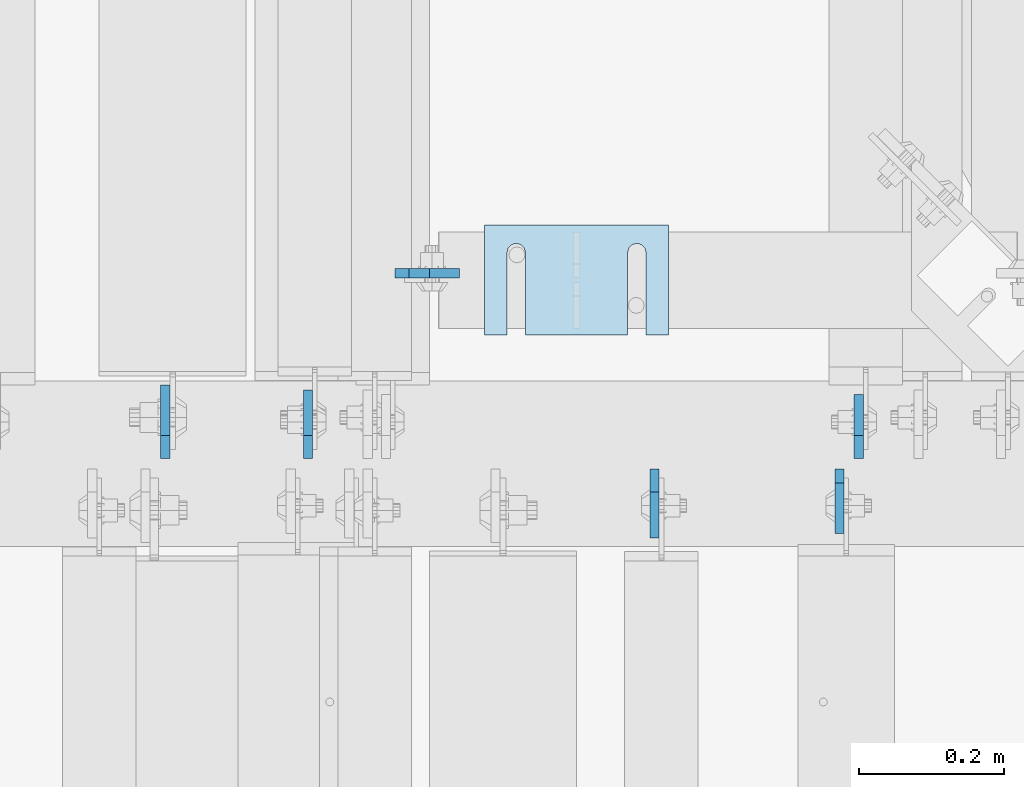
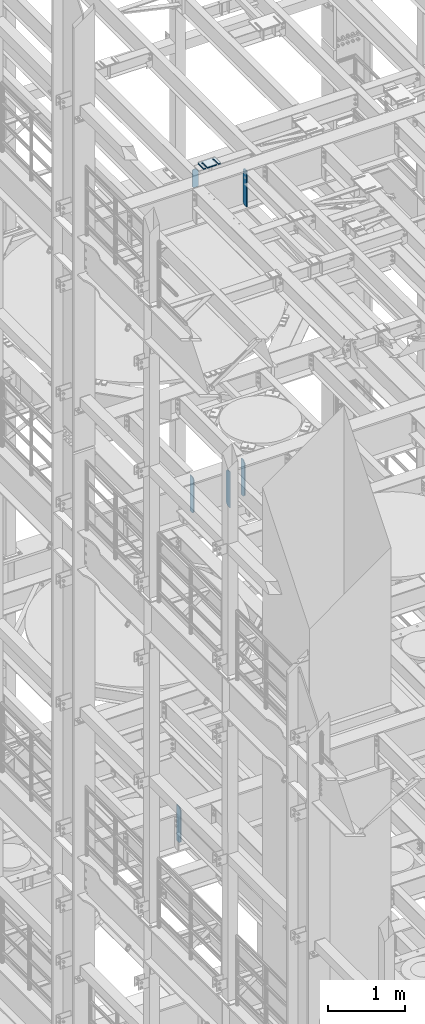
# One storey, part 1699 of 1876: 9 plates, 7 elements without a shape of their own.
"""IFC2X3 building model written with IfcOpenShell, lengths in millimetres."""

from ifc_helpers import new_model, si_unit, frame, origin_with_axes, place, context, subcontext, project, spatial, faceted_brep, material, type_object, element, aggregate, save


model = new_model("IFC2X3")

# Units and contexts
model_context = context("Model", 3, precision=1e-05, world=origin_with_axes())
body_context = subcontext(model_context, "Body", "Model", "MODEL_VIEW")
ifc_project = project(units=[si_unit("LENGTHUNIT", "METRE", prefix="MILLI"), si_unit("AREAUNIT", "SQUARE_METRE"), si_unit("VOLUMEUNIT", "CUBIC_METRE"), si_unit("MASSUNIT", "GRAM", prefix="KILO"), si_unit("TIMEUNIT", "SECOND"), si_unit("PLANEANGLEUNIT", "RADIAN"), si_unit("SOLIDANGLEUNIT", "STERADIAN"), si_unit("THERMODYNAMICTEMPERATUREUNIT", "DEGREE_CELSIUS"), si_unit("LUMINOUSINTENSITYUNIT", "LUMEN")], contexts=[model_context])

# Site, building, storey
site_placement = place(None, origin_with_axes())
site = spatial("IfcSite", under=ifc_project, at=site_placement, CompositionType="ELEMENT")
building_placement = place(site_placement, origin_with_axes())
building = spatial("IfcBuilding", under=site, at=building_placement, Name="Undefined", CompositionType="ELEMENT")
storey_placement = place(building_placement, origin_with_axes())
storey = spatial("IfcBuildingStorey", under=building, at=storey_placement, Name="Undefined", CompositionType="ELEMENT", Elevation=0.0)

# Assembly, plate
assembly_1_placement = place(storey_placement, origin_with_axes())
assembly_1 = element("IfcElementAssembly", 1, at=assembly_1_placement, inside=storey, Name="BEAM", AssemblyPlace="NOTDEFINED", PredefinedType="RIGID_FRAME")
ifc_material = material(Name="STEEL/A36")
plate_type_1 = type_object("IfcPlateType", PredefinedType="NOTDEFINED")
plate_1_placement = place(assembly_1_placement, frame((1933.575, 7883.69544076919, 17686.3375), z_axis=(0.0, 0.0, 1.0), x_axis=(1.0, 0.0, 0.0)))
plate_1 = element("IfcPlate", 2, at=plate_1_placement, type_object=plate_type_1, material=ifc_material, Name="PLATE", context=body_context, shape_type="Brep", body=[
    faceted_brep([(0.0, -6.35000000000036, 271.462512969971), (19.0499992370605, -6.35000000000036, 290.512512207031), (19.0499992370605, 6.35000000000036, 290.512512207031), (0.0, 6.35000000000036, 271.462512969971), (0.0, -6.35000000000196, 19.0499992370605), (0.0, 6.35000000000105, 19.0499992370605), (19.0499992370642, -6.35000000000105, 0.0), (19.0499992370633, 6.35000000000105, 0.0), (88.9000015258789, -6.34999999999991, 0.0), (88.9000015258789, 6.34999999999991, 0.0), (88.9000015258789, -6.35000000000036, 249.237510681152), (47.625, -6.35000000000036, 290.512512207031), (47.625, 6.35000000000036, 290.512512207031), (88.9000015258789, 6.35000000000036, 249.237510681152)], [[[0, 1, 2, 3]], [[4, 0, 3, 5]], [[6, 4, 5, 7]], [[8, 6, 7, 9]], [[6, 8, 10, 11, 1, 0, 4]], [[1, 11, 12, 2]], [[2, 12, 13, 9, 7, 5, 3]], [[10, 8, 9, 13]], [[11, 10, 13, 12]]]),
])
aggregate(assembly_1, [plate_1])

assembly_2_placement = place(storey_placement, origin_with_axes())
assembly_2 = element("IfcElementAssembly", 3, at=assembly_2_placement, inside=storey, Name="BEAM", AssemblyPlace="NOTDEFINED", PredefinedType="RIGID_FRAME")
plate_2_placement = place(assembly_2_placement, frame((2548.00015703994, 7612.85596675825, 17387.8875), z_axis=(0.0, 0.0, 1.0), x_axis=(4.46050000005016e-05, -0.999999999005197, 0.0)))
plate_2 = element("IfcPlate", 4, at=plate_2_placement, type_object=plate_type_1, material=ifc_material, Name="PLATE", context=body_context, shape_type="Brep", body=[
    faceted_brep([(0.0, -6.35000000000196, 19.0499992370605), (0.0, -6.34999999999991, 550.862476348877), (0.0, 6.34999999999991, 550.862476348877), (0.0, 6.35000000000105, 19.0499992370605), (19.0499992370605, -6.34999999999991, 569.912475585938), (19.0499992370605, 6.34999999999991, 569.912475585938), (88.9000015258616, -6.35000000001173, 569.912475585938), (88.9000015258634, 6.34999999998627, 569.912475585938), (88.9000015258789, -6.34999999999991, 0.0), (88.9000015258789, 6.34999999999991, 0.0), (19.0499992370642, -6.35000000000105, 0.0), (19.0499992370633, 6.35000000000105, 0.0)], [[[0, 1, 2, 3]], [[1, 4, 5, 2]], [[4, 6, 7, 5]], [[6, 8, 9, 7]], [[8, 10, 11, 9]], [[10, 0, 3, 11]], [[5, 7, 9, 11, 3, 2]], [[10, 8, 6, 4, 1, 0]]]),
])
aggregate(assembly_2, [plate_2])

# Assembly, plates
assembly_3_placement = place(storey_placement, origin_with_axes())
assembly_3 = element("IfcElementAssembly", 5, at=assembly_3_placement, inside=storey, Name="BEAM", AssemblyPlace="NOTDEFINED", PredefinedType="RIGID_FRAME")
plate_3_placement = place(assembly_3_placement, frame((2574.92499990463, 7627.14375, 12714.2875), z_axis=(0.0, 0.0, 1.0), x_axis=(0.0, 1.0, 0.0)))
plate_3 = element("IfcPlate", 6, at=plate_3_placement, type_object=plate_type_1, material=ifc_material, Name="PLATE", context=body_context, shape_type="Brep", body=[
    faceted_brep([(0.0, -6.34999999999991, 31.75), (0.0, -6.35000000000036, 538.162475585938), (0.0, 6.35000000000036, 538.162475585938), (0.0, 6.34999999999991, 31.75), (31.75, -6.35000000000036, 569.912475585938), (31.75, 6.35000000000036, 569.912475585938), (88.9000015258616, -6.35000000001173, 569.912475585938), (88.9000015258634, 6.34999999998627, 569.912475585938), (88.9000015258789, -6.34999999999991, 0.0), (88.9000015258789, 6.34999999999991, 0.0), (31.75, -6.34999999999991, 0.0), (31.75, 6.34999999999991, 0.0)], [[[0, 1, 2, 3]], [[1, 4, 5, 2]], [[4, 6, 7, 5]], [[6, 8, 9, 7]], [[8, 10, 11, 9]], [[10, 0, 3, 11]], [[5, 7, 9, 11, 3, 2]], [[10, 8, 6, 4, 1, 0]]]),
])
plate_type_2 = type_object("IfcPlateType", PredefinedType="NOTDEFINED")
plate_4_placement = place(assembly_3_placement, frame((1812.92499990465, 7627.14375, 12714.2875), z_axis=(0.0, 0.0, 1.0), x_axis=(0.0, 1.0, 0.0)))
plate_4 = element("IfcPlate", 7, at=plate_4_placement, type_object=plate_type_2, material=ifc_material, Name="PLATE", context=body_context, shape_type="Brep", body=[
    faceted_brep([(0.0, -6.34999999999991, 31.75), (0.0, -6.35000000000036, 538.162475585938), (0.0, 6.35000000000036, 538.162475585938), (0.0, 6.34999999999991, 31.75), (31.75, -6.35000000000036, 569.912475585938), (31.75, 6.35000000000036, 569.912475585938), (95.25, -6.35000000000036, 569.912475585938), (95.25, 6.35000000000036, 569.912475585938), (95.25, -6.35000000000036, 0.0), (95.25, 6.35000000000036, 0.0), (31.75, -6.34999999999991, 0.0), (31.75, 6.34999999999991, 0.0)], [[[0, 1, 2, 3]], [[1, 4, 5, 2]], [[4, 6, 7, 5]], [[6, 8, 9, 7]], [[8, 10, 11, 9]], [[10, 0, 3, 11]], [[5, 7, 9, 11, 3, 2]], [[10, 8, 6, 4, 1, 0]]]),
])
plate_5_placement = place(assembly_3_placement, frame((2292.34999990463, 7612.85625, 12714.2875), z_axis=(0.0, 0.0, 1.0), x_axis=(0.0, -1.0, 0.0)))
plate_5 = element("IfcPlate", 8, at=plate_5_placement, type_object=plate_type_2, material=ifc_material, Name="PLATE", context=body_context, shape_type="Brep", body=[
    faceted_brep([(0.0, -6.34999999999991, 31.75), (0.0, -6.35000000000036, 538.162475585938), (0.0, 6.35000000000036, 538.162475585938), (0.0, 6.34999999999991, 31.75), (31.75, -6.35000000000036, 569.912475585938), (31.75, 6.35000000000036, 569.912475585938), (95.25, -6.35000000000036, 569.912475585938), (95.25, 6.35000000000036, 569.912475585938), (95.25, -6.35000000000036, 0.0), (95.25, 6.35000000000036, 0.0), (31.75, -6.34999999999991, 0.0), (31.75, 6.34999999999991, 0.0)], [[[0, 1, 2, 3]], [[1, 4, 5, 2]], [[4, 6, 7, 5]], [[6, 8, 9, 7]], [[8, 10, 11, 9]], [[10, 0, 3, 11]], [[5, 7, 9, 11, 3, 2]], [[10, 8, 6, 4, 1, 0]]]),
])
aggregate(assembly_3, [plate_3, plate_4, plate_5])

# Assembly, plate
assembly_4_placement = place(storey_placement, origin_with_axes())
assembly_4 = element("IfcElementAssembly", 9, at=assembly_4_placement, inside=storey, Name="BEAM", AssemblyPlace="NOTDEFINED", PredefinedType="RIGID_FRAME")
plate_type_3 = type_object("IfcPlateType", PredefinedType="NOTDEFINED")
plate_6_placement = place(assembly_4_placement, frame((1615.28124990463, 7627.14375, 7558.0875), z_axis=(0.0, 0.0, 1.0), x_axis=(0.0, 1.0, 0.0)))
plate_6 = element("IfcPlate", 10, at=plate_6_placement, type_object=plate_type_3, material=ifc_material, Name="PLATE", context=body_context, shape_type="Brep", body=[
    faceted_brep([(0.0, -6.34999999999991, 31.75), (0.0, -6.35000000000036, 538.162475585938), (0.0, 6.35000000000036, 538.162475585938), (0.0, 6.34999999999991, 31.75), (31.75, -6.35000000000036, 569.912475585938), (31.75, 6.35000000000036, 569.912475585938), (101.599998474121, -6.34999999999991, 569.912475585938), (101.599998474121, 6.34999999999991, 569.912475585938), (101.599998474121, -6.35000000000036, 0.0), (101.599998474121, 6.35000000000036, 0.0), (31.75, -6.34999999999991, 0.0), (31.75, 6.34999999999991, 0.0)], [[[0, 1, 2, 3]], [[1, 4, 5, 2]], [[4, 6, 7, 5]], [[6, 8, 9, 7]], [[8, 10, 11, 9]], [[10, 0, 3, 11]], [[5, 7, 9, 11, 3, 2]], [[10, 8, 6, 4, 1, 0]]]),
])
aggregate(assembly_4, [plate_6])

assembly_5_placement = place(storey_placement, origin_with_axes())
assembly_5 = element("IfcElementAssembly", 11, at=assembly_5_placement, inside=storey, Name="SHIM PLATE", AssemblyPlace="NOTDEFINED", PredefinedType="RIGID_FRAME")
plate_type_4 = type_object("IfcPlateType", PredefinedType="NOTDEFINED")
plate_7_placement = place(assembly_5_placement, frame((2311.39928127174, 7950.43846988845, 17999.868), z_axis=(0.0, -1.0, 0.0), x_axis=(-1.0, 0.0, 0.0)))
plate_7 = element("IfcPlate", 12, at=plate_7_placement, type_object=plate_type_4, material=ifc_material, Name="SHIM PLATE", context=body_context, shape_type="Brep", body=[
    faceted_brep([(30.8791924037423, -2.38100000000122, 152.398895263674), (30.8814140421409, -2.38100000000122, 38.0994505407325), (30.8814140421409, 2.38100000000122, 38.0994505407325), (30.8791924037423, 2.38100000000122, 152.398895263674), (32.5828868936751, -2.38100000000122, 31.7494480341243), (32.5828868936751, 2.38100000000122, 31.7494480341243), (37.2314075583954, -2.38100000000122, 27.1009216732054), (37.2314075583954, 2.38100000000122, 27.1009216732054), (43.5814079800521, -2.38100000000122, 25.3994410405157), (43.5814079800521, 2.38100000000122, 25.3994410405157), (49.9314097200559, -2.38100000000122, 27.1009167530574), (49.9314097200559, 2.38100000000122, 27.1009167530574), (54.5799339865616, -2.38100000000122, 31.7494395121785), (54.5799339865616, 2.38100000000122, 31.7494395121785), (56.2814117582284, -2.38100000000122, 38.0994407004391), (56.2814117582284, 2.38100000000122, 38.0994407004391), (56.2791901197206, -2.38100000000122, 152.398894414155), (56.2791901197206, 2.38100000000122, 152.398895263676), (0.0, -2.38100000000122, 4.54747350886464e-13), (1.98259931494249e-05, -2.38100000000122, 152.398895263672), (1.98259931494249e-05, 2.38100000000122, 152.398895263672), (0.0, 2.38100000000122, 4.54747350886464e-13), (253.999542236328, -2.38100000000122, 6.16182660451159e-11), (253.999542236328, 2.38100000000122, 6.16182660451159e-11), (253.999557495107, -2.38100000000122, 152.398895263688), (253.999557495107, 2.38100000000122, 152.398895263688), (223.116882380463, 2.38100000000122, 152.398895263686), (223.116882380463, -2.38100000000122, 152.398895415181), (223.119104018971, 2.38100000000122, 38.0994417014649), (223.119104018971, -2.38100000000122, 38.0994417014649), (221.417626247304, 2.38100000000122, 31.7494405132047), (221.417626247304, -2.38100000000122, 31.7494405132047), (216.769101980798, 2.38100000000122, 27.1009177540836), (216.769101980798, -2.38100000000122, 27.1009177540836), (210.419100240794, 2.38100000000122, 25.399442041542), (210.419100240794, -2.38100000000122, 25.399442041542), (204.069099819138, 2.38100000000122, 27.1009226742317), (204.069099819138, -2.38100000000122, 27.1009226742317), (199.420579154417, 2.38100000000122, 31.7494490351505), (199.420579154417, -2.38100000000122, 31.7494490351505), (197.719106302883, 2.38100000000122, 38.0994515417583), (197.719106302883, -2.38100000000122, 38.0994515417583), (197.716884664484, -2.38100000000122, 152.398895263684), (197.716884664484, 2.38100000000122, 152.398895263684)], [[[0, 1, 2, 3]], [[4, 5, 2, 1]], [[6, 7, 5, 4]], [[8, 9, 7, 6]], [[10, 11, 9, 8]], [[12, 13, 11, 10]], [[14, 15, 13, 12]], [[16, 17, 15, 14]], [[18, 19, 20, 21]], [[22, 18, 21, 23]], [[24, 22, 23, 25]], [[24, 25, 26, 27]], [[27, 26, 28, 29]], [[29, 28, 30, 31]], [[31, 30, 32, 33]], [[33, 32, 34, 35]], [[35, 34, 36, 37]], [[37, 36, 38, 39]], [[39, 38, 40, 41]], [[42, 41, 40, 43]], [[12, 10, 8, 6, 4, 1, 0, 19, 18, 22, 24, 27, 29, 31, 33, 35, 37, 39, 41, 42, 16, 14]], [[20, 19, 0, 3]], [[43, 40, 38, 36, 34, 32, 30, 28, 26, 25, 23, 21, 20, 3, 2, 5, 7, 9, 11, 13, 15, 17]], [[42, 43, 17, 16]]]),
])
aggregate(assembly_5, [plate_7])

assembly_6_placement = place(storey_placement, origin_with_axes())
assembly_6 = element("IfcElementAssembly", 13, at=assembly_6_placement, inside=storey, Name="SHIM PLATE", AssemblyPlace="NOTDEFINED", PredefinedType="RIGID_FRAME")
plate_8_placement = place(assembly_6_placement, frame((2311.39928127174, 7950.43846988868, 17995.106), z_axis=(0.0, -1.0, 0.0), x_axis=(-1.0, 0.0, 0.0)))
plate_8 = element("IfcPlate", 14, at=plate_8_placement, type_object=plate_type_4, material=ifc_material, Name="SHIM PLATE", context=body_context, shape_type="Brep", body=[
    faceted_brep([(30.8791924037423, -2.38100000000122, 152.398895263674), (30.8814140421409, -2.38100000000122, 38.0994505407325), (30.8814140421409, 2.38100000000122, 38.0994505407325), (30.8791924037423, 2.38100000000122, 152.398895263674), (32.5828868936751, -2.38100000000122, 31.7494480341243), (32.5828868936751, 2.38100000000122, 31.7494480341243), (37.2314075583954, -2.38100000000122, 27.1009216732054), (37.2314075583954, 2.38100000000122, 27.1009216732054), (43.5814079800521, -2.38100000000122, 25.3994410405157), (43.5814079800521, 2.38100000000122, 25.3994410405157), (49.9314097200559, -2.38100000000122, 27.1009167530574), (49.9314097200559, 2.38100000000122, 27.1009167530574), (54.5799339865616, -2.38100000000122, 31.7494395121785), (54.5799339865616, 2.38100000000122, 31.7494395121785), (56.2814117582284, -2.38100000000122, 38.0994407004391), (56.2814117582284, 2.38100000000122, 38.0994407004391), (56.2791901197206, -2.38100000000122, 152.398894414155), (56.2791901197206, 2.38100000000122, 152.398895263676), (0.0, -2.38100000000122, 4.54747350886464e-13), (1.98259931494249e-05, -2.38100000000122, 152.398895263672), (1.98259931494249e-05, 2.38100000000122, 152.398895263672), (0.0, 2.38100000000122, 4.54747350886464e-13), (253.999542236328, -2.38100000000122, 6.16182660451159e-11), (253.999542236328, 2.38100000000122, 6.16182660451159e-11), (253.999557495107, -2.38100000000122, 152.398895263688), (253.999557495107, 2.38100000000122, 152.398895263688), (223.116882380463, 2.38100000000122, 152.398895263686), (223.116882380463, -2.38100000000122, 152.398895415181), (223.119104018971, 2.38100000000122, 38.0994417014649), (223.119104018971, -2.38100000000122, 38.0994417014649), (221.417626247304, 2.38100000000122, 31.7494405132047), (221.417626247304, -2.38100000000122, 31.7494405132047), (216.769101980798, 2.38100000000122, 27.1009177540836), (216.769101980798, -2.38100000000122, 27.1009177540836), (210.419100240794, 2.38100000000122, 25.399442041542), (210.419100240794, -2.38100000000122, 25.399442041542), (204.069099819138, 2.38100000000122, 27.1009226742317), (204.069099819138, -2.38100000000122, 27.1009226742317), (199.420579154417, 2.38100000000122, 31.7494490351505), (199.420579154417, -2.38100000000122, 31.7494490351505), (197.719106302883, 2.38100000000122, 38.0994515417583), (197.719106302883, -2.38100000000122, 38.0994515417583), (197.716884664484, -2.38100000000122, 152.398895263684), (197.716884664484, 2.38100000000122, 152.398895263684)], [[[0, 1, 2, 3]], [[4, 5, 2, 1]], [[6, 7, 5, 4]], [[8, 9, 7, 6]], [[10, 11, 9, 8]], [[12, 13, 11, 10]], [[14, 15, 13, 12]], [[16, 17, 15, 14]], [[18, 19, 20, 21]], [[22, 18, 21, 23]], [[24, 22, 23, 25]], [[24, 25, 26, 27]], [[27, 26, 28, 29]], [[29, 28, 30, 31]], [[31, 30, 32, 33]], [[33, 32, 34, 35]], [[35, 34, 36, 37]], [[37, 36, 38, 39]], [[39, 38, 40, 41]], [[42, 41, 40, 43]], [[12, 10, 8, 6, 4, 1, 0, 19, 18, 22, 24, 27, 29, 31, 33, 35, 37, 39, 41, 42, 16, 14]], [[20, 19, 0, 3]], [[43, 40, 38, 36, 34, 32, 30, 28, 26, 25, 23, 21, 20, 3, 2, 5, 7, 9, 11, 13, 15, 17]], [[42, 43, 17, 16]]]),
])
aggregate(assembly_6, [plate_8])

assembly_7_placement = place(storey_placement, origin_with_axes())
assembly_7 = element("IfcElementAssembly", 15, at=assembly_7_placement, inside=storey, Name="SHIM PLATE", AssemblyPlace="NOTDEFINED", PredefinedType="RIGID_FRAME")
plate_type_5 = type_object("IfcPlateType", PredefinedType="NOTDEFINED")
plate_9_placement = place(assembly_7_placement, frame((2311.39928127174, 7950.43846988891, 17987.9625), z_axis=(0.0, -1.0, 0.0), x_axis=(-1.0, 0.0, 0.0)))
plate_9 = element("IfcPlate", 16, at=plate_9_placement, type_object=plate_type_5, material=ifc_material, Name="SHIM PLATE", context=body_context, shape_type="Brep", body=[
    faceted_brep([(30.8791924037423, -4.76250000000073, 152.398895263674), (30.8814140421409, -4.76250000000073, 38.0994505407325), (30.8814140421409, 4.76250000000073, 38.0994505407325), (30.8791924037423, 4.76250000000073, 152.398895263674), (32.5828868936751, -4.76250000000073, 31.7494480341243), (32.5828868936751, 4.76250000000073, 31.7494480341243), (37.2314075583954, -4.76250000000073, 27.1009216732054), (37.2314075583954, 4.76250000000073, 27.1009216732054), (43.5814079800521, -4.76250000000073, 25.3994410405157), (43.5814079800521, 4.76250000000073, 25.3994410405157), (49.9314097200559, -4.76250000000073, 27.1009167530574), (49.9314097200559, 4.76250000000073, 27.1009167530574), (54.5799339865616, -4.76250000000073, 31.7494395121785), (54.5799339865616, 4.76250000000073, 31.7494395121785), (56.2814117582284, -4.76250000000073, 38.0994407004391), (56.2814117582284, 4.76250000000073, 38.0994407004391), (56.2791901197206, -4.76250000000073, 152.398894414155), (56.2791901197206, 4.76250000000073, 152.398895263676), (0.0, -4.76249999999982, 0.0), (1.98255729628727e-05, -4.76250000000073, 152.398895263672), (1.98255729628727e-05, 4.76250000000073, 152.398895263672), (0.0, 4.76249999999982, 0.0), (253.999542236328, -4.76250000000073, 6.16182660451159e-11), (253.999542236328, 4.76250000000073, 6.16182660451159e-11), (253.999557495107, -4.76250000000073, 152.398895263688), (253.999557495107, 4.76250000000073, 152.398895263688), (223.116882380463, 4.76250000000073, 152.398895263686), (223.116882380463, -4.76250000000073, 152.398895415181), (223.119104018971, 4.76250000000073, 38.0994417014649), (223.119104018971, -4.76250000000073, 38.0994417014649), (221.417626247304, 4.76250000000073, 31.7494405132047), (221.417626247304, -4.76250000000073, 31.7494405132047), (216.769101980798, 4.76250000000073, 27.1009177540836), (216.769101980798, -4.76250000000073, 27.1009177540836), (210.419100240794, 4.76250000000073, 25.399442041542), (210.419100240794, -4.76250000000073, 25.399442041542), (204.069099819138, 4.76250000000073, 27.1009226742317), (204.069099819138, -4.76250000000073, 27.1009226742317), (199.420579154417, 4.76250000000073, 31.7494490351505), (199.420579154417, -4.76250000000073, 31.7494490351505), (197.719106302883, 4.76250000000073, 38.0994515417583), (197.719106302883, -4.76250000000073, 38.0994515417583), (197.716884664484, -4.76250000000073, 152.398895263684), (197.716884664484, 4.76250000000073, 152.398895263684)], [[[0, 1, 2, 3]], [[4, 5, 2, 1]], [[6, 7, 5, 4]], [[8, 9, 7, 6]], [[10, 11, 9, 8]], [[12, 13, 11, 10]], [[14, 15, 13, 12]], [[16, 17, 15, 14]], [[18, 19, 20, 21]], [[22, 18, 21, 23]], [[24, 22, 23, 25]], [[24, 25, 26, 27]], [[27, 26, 28, 29]], [[29, 28, 30, 31]], [[31, 30, 32, 33]], [[33, 32, 34, 35]], [[35, 34, 36, 37]], [[37, 36, 38, 39]], [[39, 38, 40, 41]], [[42, 41, 40, 43]], [[12, 10, 8, 6, 4, 1, 0, 19, 18, 22, 24, 27, 29, 31, 33, 35, 37, 39, 41, 42, 16, 14]], [[20, 19, 0, 3]], [[43, 40, 38, 36, 34, 32, 30, 28, 26, 25, 23, 21, 20, 3, 2, 5, 7, 9, 11, 13, 15, 17]], [[42, 43, 17, 16]]]),
])
aggregate(assembly_7, [plate_9])

save(model, "model.ifc")
